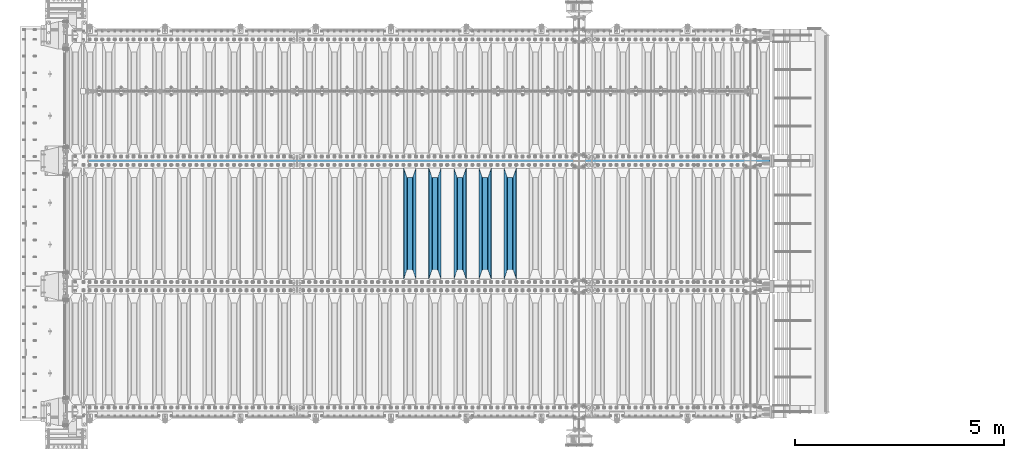
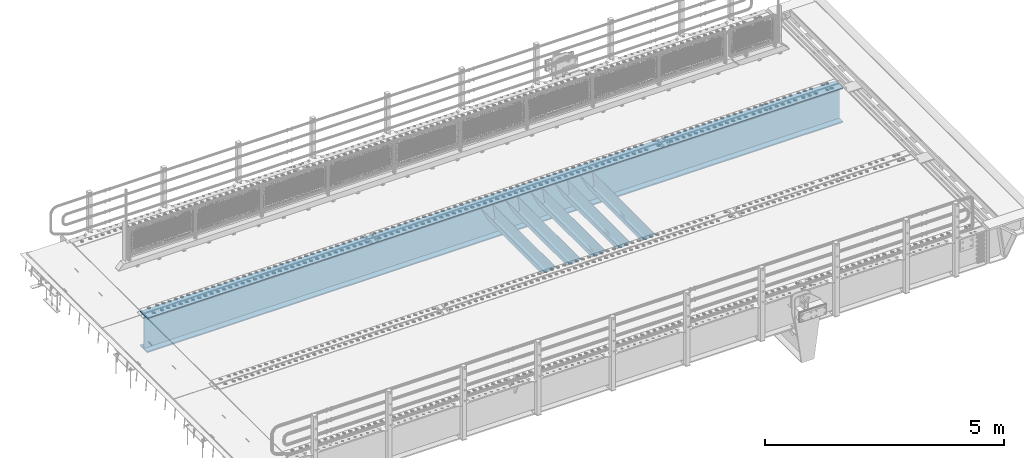
# One storey, part 117 of 247: 6 beams.
"""IFC2X3 building model written with IfcOpenShell, lengths in millimetres."""

from ifc_helpers import new_model, si_unit, frame, origin_with_axes, place, context, subcontext, project, spatial, faceted_brep, material, type_object, element, save


model = new_model("IFC2X3")

# Units and contexts
model_context = context("Model", 3, precision=1e-05, world=origin_with_axes())
body_context = subcontext(model_context, "Body", "Model", "MODEL_VIEW")
ifc_project = project(units=[si_unit("LENGTHUNIT", "METRE", prefix="MILLI"), si_unit("AREAUNIT", "SQUARE_METRE"), si_unit("VOLUMEUNIT", "CUBIC_METRE"), si_unit("MASSUNIT", "GRAM", prefix="KILO"), si_unit("TIMEUNIT", "SECOND"), si_unit("PLANEANGLEUNIT", "RADIAN"), si_unit("SOLIDANGLEUNIT", "STERADIAN"), si_unit("THERMODYNAMICTEMPERATUREUNIT", "DEGREE_CELSIUS"), si_unit("LUMINOUSINTENSITYUNIT", "LUMEN")], contexts=[model_context])

# Site, building, storey
site_placement = place(None, origin_with_axes())
site = spatial("IfcSite", under=ifc_project, at=site_placement, CompositionType="ELEMENT")
building_placement = place(site_placement, origin_with_axes())
building = spatial("IfcBuilding", under=site, at=building_placement, Name="Standard", CompositionType="ELEMENT")
storey_placement = place(building_placement, origin_with_axes())
storey = spatial("IfcBuildingStorey", under=building, at=storey_placement, Name="Undefined", CompositionType="ELEMENT", Elevation=0.0)

# Beams
ifc_material = material(Name="STEEL/S355N")
beam_type_1 = type_object("IfcBeamType", PredefinedType="NOTDEFINED")
beam_1_placement = place(storey_placement, frame((10600.0, 3175.0, -115.0), z_axis=(0.0, 0.0, 1.0), x_axis=(0.0, 1.0, 0.0)))
element("IfcBeam", 1, at=beam_1_placement, inside=storey, type_object=beam_type_1, material=ifc_material, context=body_context, shape_type="Brep", body=[
    faceted_brep([(0.0, 150.0, 115.0), (0.0, 143.689999999999, 115.0), (2650.00000000297, 143.689999999999, 115.0), (2650.00000000297, 150.0, 115.0), (2650.00000000297, 142.059565218402, 110.0000000031), (2650.00000000297, 148.369565218403, 110.0000000031), (2441.90079219208, -80.1103600731112, -98.0992078077845), (2437.7588105432, -77.5672621345584, -102.241189456673), (2434.06523489746, -74.4080125315522, -105.934765102404), (2430.91086095089, -70.710272125576, -109.089139048974), (2428.37322971128, -66.5649389910068, -111.626770288588), (2426.51472138054, -62.0739139532889, -113.485278619323), (2425.38102192091, -57.3475956567672, -114.618978078955), (2424.99999999987, -52.5021667386536, -115.0), (2424.99999999987, 52.5021667386536, -115.0), (2425.38102192091, 57.3475956567672, -114.618978078955), (2426.51472138054, 62.0739139532889, -113.485278619323), (2428.37322971128, 66.5649389910068, -111.626770288588), (2430.91086095089, 70.710272125576, -109.089139048974), (2434.06523489746, 74.4080125315522, -105.934765102404), (2437.7588105432, 77.5672621345584, -102.241189456673), (2441.90079219208, 80.1103600731112, -98.0992078077846), (2446.38936140511, 81.9747917625791, -93.6106385947584), (2448.24948500409, 76.2713538057251, -91.7505149957729), (2444.62967112262, 74.76777986261, -95.3703288772456), (2441.28936334126, 72.7168944282894, -98.710636658607), (2438.31067330438, 70.1691124903846, -101.689326695487), (2435.76682334747, 67.1870637758839, -104.233176652398), (2433.72034654133, 63.8440531834895, -106.279653458539), (2432.22154950041, 60.222258798236, -107.778450499454), (2431.30727574265, 56.4107117849089, -108.692724257221), (2430.99999999987, 52.5031078186876, -109.0), (2430.99999999987, -52.5031078186876, -109.0), (2431.30727574265, -56.4107117849089, -108.692724257221), (2432.22154950041, -60.222258798236, -107.778450499454), (2433.72034654133, -63.8440531834895, -106.279653458539), (2435.76682334747, -67.1870637758839, -104.233176652398), (2438.31067330438, -70.1691124903846, -101.689326695487), (2441.28936334126, -72.7168944282894, -98.7106366586071), (2444.62967112262, -74.76777986261, -95.3703288772457), (2448.24948500409, -76.2713538057251, -91.7505149957729), (2650.00000000297, -142.059565218402, 110.0000000031), (2650.00000000297, -148.369565218403, 110.0000000031), (2446.38936140511, -81.9747917625791, -93.6106385947584), (2650.00000000297, -143.689999999999, 115.0), (2650.00000000297, -150.0, 115.0), (0.0, -143.689999999999, 115.0), (0.0, -150.0, 115.0), (0.0, -148.369565218261, 110.000000002663), (203.610638597422, -81.9747917625791, -93.6106385947584), (208.099207810448, -80.1103600731112, -98.0992078077845), (212.241189459336, -77.5672621345584, -102.241189456673), (215.934765105068, -74.4080125315522, -105.934765102404), (219.089139051637, -70.710272125576, -109.089139048974), (221.626770291251, -66.5649389910068, -111.626770288588), (223.485278621985, -62.0739139532889, -113.485278619323), (224.618978081617, -57.3475956567672, -114.618978078955), (225.000000002663, -52.5021667386536, -115.0), (225.000000002663, 52.5021667386536, -115.0), (224.618978081617, 57.3475956567672, -114.618978078955), (223.485278621985, 62.0739139532889, -113.485278619323), (221.626770291251, 66.5649389910068, -111.626770288588), (219.089139051637, 70.710272125576, -109.089139048974), (215.934765105068, 74.4080125315522, -105.934765102404), (212.241189459336, 77.5672621345584, -102.241189456673), (208.099207810448, 80.1103600731112, -98.0992078077846), (203.610638597422, 81.9747917625791, -93.6106385947584), (0.0, 148.369565218261, 110.000000002663), (0.0, 142.05956521826, 110.000000002663), (201.750514998436, 76.2713538057251, -91.7505149957729), (205.370328879908, 74.76777986261, -95.3703288772456), (208.710636661271, 72.7168944282894, -98.710636658607), (211.68932669815, 70.1691124903846, -101.689326695487), (214.233176655061, 67.1870637758839, -104.233176652398), (216.279653461202, 63.8440531834895, -106.279653458539), (217.778450502117, 60.222258798236, -107.778450499454), (218.692724259885, 56.4107117849089, -108.692724257221), (219.000000002663, 52.5031078186876, -109.0), (219.000000002663, -52.5031078186876, -109.0), (218.692724259885, -56.4107117849089, -108.692724257221), (217.778450502117, -60.222258798236, -107.778450499454), (216.279653461202, -63.8440531834895, -106.279653458539), (214.233176655061, -67.1870637758839, -104.233176652398), (211.68932669815, -70.1691124903846, -101.689326695487), (208.710636661271, -72.7168944282894, -98.7106366586071), (205.370328879908, -74.76777986261, -95.3703288772457), (201.750514998436, -76.2713538057251, -91.7505149957729), (0.0, -142.05956521826, 110.000000002663)], [[[0, 1, 2, 3]], [[3, 2, 4, 5]], [[6, 7, 8, 9, 10, 11, 12, 13, 14, 15, 16, 17, 18, 19, 20, 21, 22, 5, 4, 23, 24, 25, 26, 27, 28, 29, 30, 31, 32, 33, 34, 35, 36, 37, 38, 39, 40, 41, 42, 43]], [[44, 45, 42, 41]], [[46, 47, 45, 44]], [[43, 42, 45, 47, 48, 49]], [[6, 43, 49, 50]], [[7, 6, 50, 51]], [[8, 7, 51, 52]], [[9, 8, 52, 53]], [[10, 9, 53, 54]], [[11, 10, 54, 55]], [[12, 11, 55, 56]], [[13, 12, 56, 57]], [[14, 13, 57, 58]], [[15, 14, 58, 59]], [[16, 15, 59, 60]], [[17, 16, 60, 61]], [[18, 17, 61, 62]], [[19, 18, 62, 63]], [[20, 19, 63, 64]], [[21, 20, 64, 65]], [[22, 21, 65, 66]], [[0, 3, 5, 22, 66, 67]], [[1, 0, 67, 68]], [[23, 4, 2, 1, 68, 69]], [[24, 23, 69, 70]], [[25, 24, 70, 71]], [[26, 25, 71, 72]], [[27, 26, 72, 73]], [[28, 27, 73, 74]], [[29, 28, 74, 75]], [[30, 29, 75, 76]], [[31, 30, 76, 77]], [[32, 31, 77, 78]], [[33, 32, 78, 79]], [[34, 33, 79, 80]], [[35, 34, 80, 81]], [[36, 35, 81, 82]], [[37, 36, 82, 83]], [[38, 37, 83, 84]], [[39, 38, 84, 85]], [[40, 39, 85, 86]], [[46, 44, 41, 40, 86, 87]], [[47, 46, 87, 48]], [[86, 85, 84, 83, 82, 81, 80, 79, 78, 77, 76, 75, 74, 73, 72, 71, 70, 69, 68, 67, 66, 65, 64, 63, 62, 61, 60, 59, 58, 57, 56, 55, 54, 53, 52, 51, 50, 49, 48, 87]]]),
])
beam_2_placement = place(storey_placement, frame((10000.0, 3175.0, -115.0), z_axis=(0.0, 0.0, 1.0), x_axis=(0.0, 1.0, 0.0)))
element("IfcBeam", 2, at=beam_2_placement, inside=storey, type_object=beam_type_1, material=ifc_material, context=body_context, shape_type="Brep", body=[
    faceted_brep([(0.0, 150.0, 115.0), (0.0, 143.689999999999, 115.0), (2650.00000000297, 143.689999999999, 115.0), (2650.00000000297, 150.0, 115.0), (2650.00000000297, 142.059565218402, 110.0000000031), (2650.00000000297, 148.369565218403, 110.0000000031), (2441.90079219208, -80.1103600731112, -98.0992078077845), (2437.7588105432, -77.5672621345584, -102.241189456673), (2434.06523489746, -74.4080125315522, -105.934765102404), (2430.91086095089, -70.710272125576, -109.089139048974), (2428.37322971128, -66.5649389910068, -111.626770288588), (2426.51472138054, -62.0739139532889, -113.485278619323), (2425.38102192091, -57.3475956567672, -114.618978078955), (2424.99999999987, -52.5021667386536, -115.0), (2424.99999999987, 52.5021667386536, -115.0), (2425.38102192091, 57.3475956567672, -114.618978078955), (2426.51472138054, 62.0739139532889, -113.485278619323), (2428.37322971128, 66.5649389910068, -111.626770288588), (2430.91086095089, 70.710272125576, -109.089139048974), (2434.06523489746, 74.4080125315522, -105.934765102404), (2437.7588105432, 77.5672621345584, -102.241189456673), (2441.90079219208, 80.1103600731112, -98.0992078077846), (2446.38936140511, 81.9747917625791, -93.6106385947584), (2448.24948500409, 76.2713538057251, -91.7505149957729), (2444.62967112262, 74.76777986261, -95.3703288772456), (2441.28936334126, 72.7168944282894, -98.710636658607), (2438.31067330438, 70.1691124903846, -101.689326695487), (2435.76682334747, 67.1870637758839, -104.233176652398), (2433.72034654133, 63.8440531834895, -106.279653458539), (2432.22154950041, 60.222258798236, -107.778450499454), (2431.30727574265, 56.4107117849089, -108.692724257221), (2430.99999999987, 52.5031078186876, -109.0), (2430.99999999987, -52.5031078186876, -109.0), (2431.30727574265, -56.4107117849089, -108.692724257221), (2432.22154950041, -60.222258798236, -107.778450499454), (2433.72034654133, -63.8440531834895, -106.279653458539), (2435.76682334747, -67.1870637758839, -104.233176652398), (2438.31067330438, -70.1691124903846, -101.689326695487), (2441.28936334126, -72.7168944282894, -98.7106366586071), (2444.62967112262, -74.76777986261, -95.3703288772457), (2448.24948500409, -76.2713538057251, -91.7505149957729), (2650.00000000297, -142.059565218402, 110.0000000031), (2650.00000000297, -148.369565218403, 110.0000000031), (2446.38936140511, -81.9747917625791, -93.6106385947584), (2650.00000000297, -143.689999999999, 115.0), (2650.00000000297, -150.0, 115.0), (0.0, -143.689999999999, 115.0), (0.0, -150.0, 115.0), (0.0, -148.369565218261, 110.000000002663), (203.610638597422, -81.9747917625791, -93.6106385947584), (208.099207810448, -80.1103600731112, -98.0992078077845), (212.241189459336, -77.5672621345584, -102.241189456673), (215.934765105068, -74.4080125315522, -105.934765102404), (219.089139051637, -70.710272125576, -109.089139048974), (221.626770291251, -66.5649389910068, -111.626770288588), (223.485278621985, -62.0739139532889, -113.485278619323), (224.618978081617, -57.3475956567672, -114.618978078955), (225.000000002663, -52.5021667386536, -115.0), (225.000000002663, 52.5021667386536, -115.0), (224.618978081617, 57.3475956567672, -114.618978078955), (223.485278621985, 62.0739139532889, -113.485278619323), (221.626770291251, 66.5649389910068, -111.626770288588), (219.089139051637, 70.710272125576, -109.089139048974), (215.934765105068, 74.4080125315522, -105.934765102404), (212.241189459336, 77.5672621345584, -102.241189456673), (208.099207810448, 80.1103600731112, -98.0992078077846), (203.610638597422, 81.9747917625791, -93.6106385947584), (0.0, 148.369565218261, 110.000000002663), (0.0, 142.05956521826, 110.000000002663), (201.750514998436, 76.2713538057251, -91.7505149957729), (205.370328879908, 74.76777986261, -95.3703288772456), (208.710636661271, 72.7168944282894, -98.710636658607), (211.68932669815, 70.1691124903846, -101.689326695487), (214.233176655061, 67.1870637758839, -104.233176652398), (216.279653461202, 63.8440531834895, -106.279653458539), (217.778450502117, 60.222258798236, -107.778450499454), (218.692724259885, 56.4107117849089, -108.692724257221), (219.000000002663, 52.5031078186876, -109.0), (219.000000002663, -52.5031078186876, -109.0), (218.692724259885, -56.4107117849089, -108.692724257221), (217.778450502117, -60.222258798236, -107.778450499454), (216.279653461202, -63.8440531834895, -106.279653458539), (214.233176655061, -67.1870637758839, -104.233176652398), (211.68932669815, -70.1691124903846, -101.689326695487), (208.710636661271, -72.7168944282894, -98.7106366586071), (205.370328879908, -74.76777986261, -95.3703288772457), (201.750514998436, -76.2713538057251, -91.7505149957729), (0.0, -142.05956521826, 110.000000002663)], [[[0, 1, 2, 3]], [[3, 2, 4, 5]], [[6, 7, 8, 9, 10, 11, 12, 13, 14, 15, 16, 17, 18, 19, 20, 21, 22, 5, 4, 23, 24, 25, 26, 27, 28, 29, 30, 31, 32, 33, 34, 35, 36, 37, 38, 39, 40, 41, 42, 43]], [[44, 45, 42, 41]], [[46, 47, 45, 44]], [[43, 42, 45, 47, 48, 49]], [[6, 43, 49, 50]], [[7, 6, 50, 51]], [[8, 7, 51, 52]], [[9, 8, 52, 53]], [[10, 9, 53, 54]], [[11, 10, 54, 55]], [[12, 11, 55, 56]], [[13, 12, 56, 57]], [[14, 13, 57, 58]], [[15, 14, 58, 59]], [[16, 15, 59, 60]], [[17, 16, 60, 61]], [[18, 17, 61, 62]], [[19, 18, 62, 63]], [[20, 19, 63, 64]], [[21, 20, 64, 65]], [[22, 21, 65, 66]], [[0, 3, 5, 22, 66, 67]], [[1, 0, 67, 68]], [[23, 4, 2, 1, 68, 69]], [[24, 23, 69, 70]], [[25, 24, 70, 71]], [[26, 25, 71, 72]], [[27, 26, 72, 73]], [[28, 27, 73, 74]], [[29, 28, 74, 75]], [[30, 29, 75, 76]], [[31, 30, 76, 77]], [[32, 31, 77, 78]], [[33, 32, 78, 79]], [[34, 33, 79, 80]], [[35, 34, 80, 81]], [[36, 35, 81, 82]], [[37, 36, 82, 83]], [[38, 37, 83, 84]], [[39, 38, 84, 85]], [[40, 39, 85, 86]], [[46, 44, 41, 40, 86, 87]], [[47, 46, 87, 48]], [[86, 85, 84, 83, 82, 81, 80, 79, 78, 77, 76, 75, 74, 73, 72, 71, 70, 69, 68, 67, 66, 65, 64, 63, 62, 61, 60, 59, 58, 57, 56, 55, 54, 53, 52, 51, 50, 49, 48, 87]]]),
])
beam_3_placement = place(storey_placement, frame((9400.0, 3175.0, -115.0), z_axis=(0.0, 0.0, 1.0), x_axis=(0.0, 1.0, 0.0)))
element("IfcBeam", 3, at=beam_3_placement, inside=storey, type_object=beam_type_1, material=ifc_material, context=body_context, shape_type="Brep", body=[
    faceted_brep([(0.0, 150.0, 115.0), (0.0, 143.689999999999, 115.0), (2650.00000000297, 143.689999999999, 115.0), (2650.00000000297, 150.0, 115.0), (2650.00000000297, 142.059565218402, 110.0000000031), (2650.00000000297, 148.369565218403, 110.0000000031), (2441.90079219208, -80.1103600731112, -98.0992078077845), (2437.7588105432, -77.5672621345584, -102.241189456673), (2434.06523489746, -74.4080125315522, -105.934765102404), (2430.91086095089, -70.710272125576, -109.089139048974), (2428.37322971128, -66.5649389910068, -111.626770288588), (2426.51472138054, -62.0739139532889, -113.485278619323), (2425.38102192091, -57.3475956567672, -114.618978078955), (2424.99999999987, -52.5021667386536, -115.0), (2424.99999999987, 52.5021667386536, -115.0), (2425.38102192091, 57.3475956567672, -114.618978078955), (2426.51472138054, 62.0739139532889, -113.485278619323), (2428.37322971128, 66.5649389910068, -111.626770288588), (2430.91086095089, 70.710272125576, -109.089139048974), (2434.06523489746, 74.4080125315522, -105.934765102404), (2437.7588105432, 77.5672621345584, -102.241189456673), (2441.90079219208, 80.1103600731112, -98.0992078077846), (2446.38936140511, 81.9747917625791, -93.6106385947584), (2448.24948500409, 76.2713538057251, -91.7505149957729), (2444.62967112262, 74.76777986261, -95.3703288772456), (2441.28936334126, 72.7168944282894, -98.710636658607), (2438.31067330438, 70.1691124903846, -101.689326695487), (2435.76682334747, 67.1870637758839, -104.233176652398), (2433.72034654133, 63.8440531834895, -106.279653458539), (2432.22154950041, 60.222258798236, -107.778450499454), (2431.30727574265, 56.4107117849089, -108.692724257221), (2430.99999999987, 52.5031078186876, -109.0), (2430.99999999987, -52.5031078186876, -109.0), (2431.30727574265, -56.4107117849089, -108.692724257221), (2432.22154950041, -60.222258798236, -107.778450499454), (2433.72034654133, -63.8440531834895, -106.279653458539), (2435.76682334747, -67.1870637758839, -104.233176652398), (2438.31067330438, -70.1691124903846, -101.689326695487), (2441.28936334126, -72.7168944282894, -98.7106366586071), (2444.62967112262, -74.76777986261, -95.3703288772457), (2448.24948500409, -76.2713538057251, -91.7505149957729), (2650.00000000297, -142.059565218402, 110.0000000031), (2650.00000000297, -148.369565218403, 110.0000000031), (2446.38936140511, -81.9747917625791, -93.6106385947584), (2650.00000000297, -143.689999999999, 115.0), (2650.00000000297, -150.0, 115.0), (0.0, -143.689999999999, 115.0), (0.0, -150.0, 115.0), (0.0, -148.369565218261, 110.000000002663), (203.610638597422, -81.9747917625791, -93.6106385947584), (208.099207810448, -80.1103600731112, -98.0992078077845), (212.241189459336, -77.5672621345584, -102.241189456673), (215.934765105068, -74.4080125315522, -105.934765102404), (219.089139051637, -70.710272125576, -109.089139048974), (221.626770291251, -66.5649389910068, -111.626770288588), (223.485278621985, -62.0739139532889, -113.485278619323), (224.618978081617, -57.3475956567672, -114.618978078955), (225.000000002663, -52.5021667386536, -115.0), (225.000000002663, 52.5021667386536, -115.0), (224.618978081617, 57.3475956567672, -114.618978078955), (223.485278621985, 62.0739139532889, -113.485278619323), (221.626770291251, 66.5649389910068, -111.626770288588), (219.089139051637, 70.710272125576, -109.089139048974), (215.934765105068, 74.4080125315522, -105.934765102404), (212.241189459336, 77.5672621345584, -102.241189456673), (208.099207810448, 80.1103600731112, -98.0992078077846), (203.610638597422, 81.9747917625791, -93.6106385947584), (0.0, 148.369565218261, 110.000000002663), (0.0, 142.05956521826, 110.000000002663), (201.750514998436, 76.2713538057251, -91.7505149957729), (205.370328879908, 74.76777986261, -95.3703288772456), (208.710636661271, 72.7168944282894, -98.710636658607), (211.68932669815, 70.1691124903846, -101.689326695487), (214.233176655061, 67.1870637758839, -104.233176652398), (216.279653461202, 63.8440531834895, -106.279653458539), (217.778450502117, 60.222258798236, -107.778450499454), (218.692724259885, 56.4107117849089, -108.692724257221), (219.000000002663, 52.5031078186876, -109.0), (219.000000002663, -52.5031078186876, -109.0), (218.692724259885, -56.4107117849089, -108.692724257221), (217.778450502117, -60.222258798236, -107.778450499454), (216.279653461202, -63.8440531834895, -106.279653458539), (214.233176655061, -67.1870637758839, -104.233176652398), (211.68932669815, -70.1691124903846, -101.689326695487), (208.710636661271, -72.7168944282894, -98.7106366586071), (205.370328879908, -74.76777986261, -95.3703288772457), (201.750514998436, -76.2713538057251, -91.7505149957729), (0.0, -142.05956521826, 110.000000002663)], [[[0, 1, 2, 3]], [[3, 2, 4, 5]], [[6, 7, 8, 9, 10, 11, 12, 13, 14, 15, 16, 17, 18, 19, 20, 21, 22, 5, 4, 23, 24, 25, 26, 27, 28, 29, 30, 31, 32, 33, 34, 35, 36, 37, 38, 39, 40, 41, 42, 43]], [[44, 45, 42, 41]], [[46, 47, 45, 44]], [[43, 42, 45, 47, 48, 49]], [[6, 43, 49, 50]], [[7, 6, 50, 51]], [[8, 7, 51, 52]], [[9, 8, 52, 53]], [[10, 9, 53, 54]], [[11, 10, 54, 55]], [[12, 11, 55, 56]], [[13, 12, 56, 57]], [[14, 13, 57, 58]], [[15, 14, 58, 59]], [[16, 15, 59, 60]], [[17, 16, 60, 61]], [[18, 17, 61, 62]], [[19, 18, 62, 63]], [[20, 19, 63, 64]], [[21, 20, 64, 65]], [[22, 21, 65, 66]], [[0, 3, 5, 22, 66, 67]], [[1, 0, 67, 68]], [[23, 4, 2, 1, 68, 69]], [[24, 23, 69, 70]], [[25, 24, 70, 71]], [[26, 25, 71, 72]], [[27, 26, 72, 73]], [[28, 27, 73, 74]], [[29, 28, 74, 75]], [[30, 29, 75, 76]], [[31, 30, 76, 77]], [[32, 31, 77, 78]], [[33, 32, 78, 79]], [[34, 33, 79, 80]], [[35, 34, 80, 81]], [[36, 35, 81, 82]], [[37, 36, 82, 83]], [[38, 37, 83, 84]], [[39, 38, 84, 85]], [[40, 39, 85, 86]], [[46, 44, 41, 40, 86, 87]], [[47, 46, 87, 48]], [[86, 85, 84, 83, 82, 81, 80, 79, 78, 77, 76, 75, 74, 73, 72, 71, 70, 69, 68, 67, 66, 65, 64, 63, 62, 61, 60, 59, 58, 57, 56, 55, 54, 53, 52, 51, 50, 49, 48, 87]]]),
])
beam_4_placement = place(storey_placement, frame((8800.0, 3175.0, -115.0), z_axis=(0.0, 0.0, 1.0), x_axis=(0.0, 1.0, 0.0)))
element("IfcBeam", 4, at=beam_4_placement, inside=storey, type_object=beam_type_1, material=ifc_material, context=body_context, shape_type="Brep", body=[
    faceted_brep([(0.0, 150.0, 115.0), (0.0, 143.689999999999, 115.0), (2650.00000000297, 143.689999999999, 115.0), (2650.00000000297, 150.0, 115.0), (2650.00000000297, 142.059565218402, 110.0000000031), (2650.00000000297, 148.369565218403, 110.0000000031), (2441.90079219208, -80.1103600731112, -98.0992078077845), (2437.7588105432, -77.5672621345584, -102.241189456673), (2434.06523489746, -74.4080125315522, -105.934765102404), (2430.91086095089, -70.710272125576, -109.089139048974), (2428.37322971128, -66.5649389910068, -111.626770288588), (2426.51472138054, -62.0739139532889, -113.485278619323), (2425.38102192091, -57.3475956567672, -114.618978078955), (2424.99999999987, -52.5021667386536, -115.0), (2424.99999999987, 52.5021667386536, -115.0), (2425.38102192091, 57.3475956567672, -114.618978078955), (2426.51472138054, 62.0739139532889, -113.485278619323), (2428.37322971128, 66.5649389910068, -111.626770288588), (2430.91086095089, 70.710272125576, -109.089139048974), (2434.06523489746, 74.4080125315522, -105.934765102404), (2437.7588105432, 77.5672621345584, -102.241189456673), (2441.90079219208, 80.1103600731112, -98.0992078077846), (2446.38936140511, 81.9747917625791, -93.6106385947584), (2448.24948500409, 76.2713538057251, -91.7505149957729), (2444.62967112262, 74.76777986261, -95.3703288772456), (2441.28936334126, 72.7168944282894, -98.710636658607), (2438.31067330438, 70.1691124903846, -101.689326695487), (2435.76682334747, 67.1870637758839, -104.233176652398), (2433.72034654133, 63.8440531834895, -106.279653458539), (2432.22154950041, 60.222258798236, -107.778450499454), (2431.30727574265, 56.4107117849089, -108.692724257221), (2430.99999999987, 52.5031078186876, -109.0), (2430.99999999987, -52.5031078186876, -109.0), (2431.30727574265, -56.4107117849089, -108.692724257221), (2432.22154950041, -60.222258798236, -107.778450499454), (2433.72034654133, -63.8440531834895, -106.279653458539), (2435.76682334747, -67.1870637758839, -104.233176652398), (2438.31067330438, -70.1691124903846, -101.689326695487), (2441.28936334126, -72.7168944282894, -98.7106366586071), (2444.62967112262, -74.76777986261, -95.3703288772457), (2448.24948500409, -76.2713538057251, -91.7505149957729), (2650.00000000297, -142.059565218402, 110.0000000031), (2650.00000000297, -148.369565218403, 110.0000000031), (2446.38936140511, -81.9747917625791, -93.6106385947584), (2650.00000000297, -143.689999999999, 115.0), (2650.00000000297, -150.0, 115.0), (0.0, -143.689999999999, 115.0), (0.0, -150.0, 115.0), (0.0, -148.369565218261, 110.000000002663), (203.610638597422, -81.9747917625791, -93.6106385947584), (208.099207810448, -80.1103600731112, -98.0992078077845), (212.241189459336, -77.5672621345584, -102.241189456673), (215.934765105068, -74.4080125315522, -105.934765102404), (219.089139051637, -70.710272125576, -109.089139048974), (221.626770291251, -66.5649389910068, -111.626770288588), (223.485278621985, -62.0739139532889, -113.485278619323), (224.618978081617, -57.3475956567672, -114.618978078955), (225.000000002663, -52.5021667386536, -115.0), (225.000000002663, 52.5021667386536, -115.0), (224.618978081617, 57.3475956567672, -114.618978078955), (223.485278621985, 62.0739139532889, -113.485278619323), (221.626770291251, 66.5649389910068, -111.626770288588), (219.089139051637, 70.710272125576, -109.089139048974), (215.934765105068, 74.4080125315522, -105.934765102404), (212.241189459336, 77.5672621345584, -102.241189456673), (208.099207810448, 80.1103600731112, -98.0992078077846), (203.610638597422, 81.9747917625791, -93.6106385947584), (0.0, 148.369565218261, 110.000000002663), (0.0, 142.05956521826, 110.000000002663), (201.750514998436, 76.2713538057251, -91.7505149957729), (205.370328879908, 74.76777986261, -95.3703288772456), (208.710636661271, 72.7168944282894, -98.710636658607), (211.68932669815, 70.1691124903846, -101.689326695487), (214.233176655061, 67.1870637758839, -104.233176652398), (216.279653461202, 63.8440531834895, -106.279653458539), (217.778450502117, 60.222258798236, -107.778450499454), (218.692724259885, 56.4107117849089, -108.692724257221), (219.000000002663, 52.5031078186876, -109.0), (219.000000002663, -52.5031078186876, -109.0), (218.692724259885, -56.4107117849089, -108.692724257221), (217.778450502117, -60.222258798236, -107.778450499454), (216.279653461202, -63.8440531834895, -106.279653458539), (214.233176655061, -67.1870637758839, -104.233176652398), (211.68932669815, -70.1691124903846, -101.689326695487), (208.710636661271, -72.7168944282894, -98.7106366586071), (205.370328879908, -74.76777986261, -95.3703288772457), (201.750514998436, -76.2713538057251, -91.7505149957729), (0.0, -142.05956521826, 110.000000002663)], [[[0, 1, 2, 3]], [[3, 2, 4, 5]], [[6, 7, 8, 9, 10, 11, 12, 13, 14, 15, 16, 17, 18, 19, 20, 21, 22, 5, 4, 23, 24, 25, 26, 27, 28, 29, 30, 31, 32, 33, 34, 35, 36, 37, 38, 39, 40, 41, 42, 43]], [[44, 45, 42, 41]], [[46, 47, 45, 44]], [[43, 42, 45, 47, 48, 49]], [[6, 43, 49, 50]], [[7, 6, 50, 51]], [[8, 7, 51, 52]], [[9, 8, 52, 53]], [[10, 9, 53, 54]], [[11, 10, 54, 55]], [[12, 11, 55, 56]], [[13, 12, 56, 57]], [[14, 13, 57, 58]], [[15, 14, 58, 59]], [[16, 15, 59, 60]], [[17, 16, 60, 61]], [[18, 17, 61, 62]], [[19, 18, 62, 63]], [[20, 19, 63, 64]], [[21, 20, 64, 65]], [[22, 21, 65, 66]], [[0, 3, 5, 22, 66, 67]], [[1, 0, 67, 68]], [[23, 4, 2, 1, 68, 69]], [[24, 23, 69, 70]], [[25, 24, 70, 71]], [[26, 25, 71, 72]], [[27, 26, 72, 73]], [[28, 27, 73, 74]], [[29, 28, 74, 75]], [[30, 29, 75, 76]], [[31, 30, 76, 77]], [[32, 31, 77, 78]], [[33, 32, 78, 79]], [[34, 33, 79, 80]], [[35, 34, 80, 81]], [[36, 35, 81, 82]], [[37, 36, 82, 83]], [[38, 37, 83, 84]], [[39, 38, 84, 85]], [[40, 39, 85, 86]], [[46, 44, 41, 40, 86, 87]], [[47, 46, 87, 48]], [[86, 85, 84, 83, 82, 81, 80, 79, 78, 77, 76, 75, 74, 73, 72, 71, 70, 69, 68, 67, 66, 65, 64, 63, 62, 61, 60, 59, 58, 57, 56, 55, 54, 53, 52, 51, 50, 49, 48, 87]]]),
])
beam_5_placement = place(storey_placement, frame((8200.0, 3175.0, -115.0), z_axis=(0.0, 0.0, 1.0), x_axis=(0.0, 1.0, 0.0)))
element("IfcBeam", 5, at=beam_5_placement, inside=storey, type_object=beam_type_1, material=ifc_material, context=body_context, shape_type="Brep", body=[
    faceted_brep([(0.0, 150.0, 115.0), (0.0, 143.689999999999, 115.0), (2650.00000000297, 143.689999999999, 115.0), (2650.00000000297, 150.0, 115.0), (2650.00000000297, 142.059565218402, 110.0000000031), (2650.00000000297, 148.369565218403, 110.0000000031), (2441.90079219208, -80.1103600731112, -98.0992078077845), (2437.7588105432, -77.5672621345584, -102.241189456673), (2434.06523489746, -74.4080125315522, -105.934765102404), (2430.91086095089, -70.710272125576, -109.089139048974), (2428.37322971128, -66.5649389910068, -111.626770288588), (2426.51472138054, -62.0739139532889, -113.485278619323), (2425.38102192091, -57.3475956567672, -114.618978078955), (2424.99999999987, -52.5021667386536, -115.0), (2424.99999999987, 52.5021667386536, -115.0), (2425.38102192091, 57.3475956567672, -114.618978078955), (2426.51472138054, 62.0739139532889, -113.485278619323), (2428.37322971128, 66.5649389910068, -111.626770288588), (2430.91086095089, 70.710272125576, -109.089139048974), (2434.06523489746, 74.4080125315522, -105.934765102404), (2437.7588105432, 77.5672621345584, -102.241189456673), (2441.90079219208, 80.1103600731112, -98.0992078077846), (2446.38936140511, 81.9747917625791, -93.6106385947584), (2448.24948500409, 76.2713538057251, -91.7505149957729), (2444.62967112262, 74.76777986261, -95.3703288772456), (2441.28936334126, 72.7168944282894, -98.710636658607), (2438.31067330438, 70.1691124903846, -101.689326695487), (2435.76682334747, 67.1870637758839, -104.233176652398), (2433.72034654133, 63.8440531834895, -106.279653458539), (2432.22154950041, 60.222258798236, -107.778450499454), (2431.30727574265, 56.4107117849089, -108.692724257221), (2430.99999999987, 52.5031078186876, -109.0), (2430.99999999987, -52.5031078186876, -109.0), (2431.30727574265, -56.4107117849089, -108.692724257221), (2432.22154950041, -60.222258798236, -107.778450499454), (2433.72034654133, -63.8440531834895, -106.279653458539), (2435.76682334747, -67.1870637758839, -104.233176652398), (2438.31067330438, -70.1691124903846, -101.689326695487), (2441.28936334126, -72.7168944282894, -98.7106366586071), (2444.62967112262, -74.76777986261, -95.3703288772457), (2448.24948500409, -76.2713538057251, -91.7505149957729), (2650.00000000297, -142.059565218402, 110.0000000031), (2650.00000000297, -148.369565218403, 110.0000000031), (2446.38936140511, -81.9747917625791, -93.6106385947584), (2650.00000000297, -143.689999999999, 115.0), (2650.00000000297, -150.0, 115.0), (0.0, -143.689999999999, 115.0), (0.0, -150.0, 115.0), (0.0, -148.369565218261, 110.000000002663), (203.610638597422, -81.9747917625791, -93.6106385947584), (208.099207810448, -80.1103600731112, -98.0992078077845), (212.241189459336, -77.5672621345584, -102.241189456673), (215.934765105068, -74.4080125315522, -105.934765102404), (219.089139051637, -70.710272125576, -109.089139048974), (221.626770291251, -66.5649389910068, -111.626770288588), (223.485278621985, -62.0739139532889, -113.485278619323), (224.618978081617, -57.3475956567672, -114.618978078955), (225.000000002663, -52.5021667386536, -115.0), (225.000000002663, 52.5021667386536, -115.0), (224.618978081617, 57.3475956567672, -114.618978078955), (223.485278621985, 62.0739139532889, -113.485278619323), (221.626770291251, 66.5649389910068, -111.626770288588), (219.089139051637, 70.710272125576, -109.089139048974), (215.934765105068, 74.4080125315522, -105.934765102404), (212.241189459336, 77.5672621345584, -102.241189456673), (208.099207810448, 80.1103600731112, -98.0992078077846), (203.610638597422, 81.9747917625791, -93.6106385947584), (0.0, 148.369565218261, 110.000000002663), (0.0, 142.05956521826, 110.000000002663), (201.750514998436, 76.2713538057251, -91.7505149957729), (205.370328879908, 74.76777986261, -95.3703288772456), (208.710636661271, 72.7168944282894, -98.710636658607), (211.68932669815, 70.1691124903846, -101.689326695487), (214.233176655061, 67.1870637758839, -104.233176652398), (216.279653461202, 63.8440531834895, -106.279653458539), (217.778450502117, 60.222258798236, -107.778450499454), (218.692724259885, 56.4107117849089, -108.692724257221), (219.000000002663, 52.5031078186876, -109.0), (219.000000002663, -52.5031078186876, -109.0), (218.692724259885, -56.4107117849089, -108.692724257221), (217.778450502117, -60.222258798236, -107.778450499454), (216.279653461202, -63.8440531834895, -106.279653458539), (214.233176655061, -67.1870637758839, -104.233176652398), (211.68932669815, -70.1691124903846, -101.689326695487), (208.710636661271, -72.7168944282894, -98.7106366586071), (205.370328879908, -74.76777986261, -95.3703288772457), (201.750514998436, -76.2713538057251, -91.7505149957729), (0.0, -142.05956521826, 110.000000002663)], [[[0, 1, 2, 3]], [[3, 2, 4, 5]], [[6, 7, 8, 9, 10, 11, 12, 13, 14, 15, 16, 17, 18, 19, 20, 21, 22, 5, 4, 23, 24, 25, 26, 27, 28, 29, 30, 31, 32, 33, 34, 35, 36, 37, 38, 39, 40, 41, 42, 43]], [[44, 45, 42, 41]], [[46, 47, 45, 44]], [[43, 42, 45, 47, 48, 49]], [[6, 43, 49, 50]], [[7, 6, 50, 51]], [[8, 7, 51, 52]], [[9, 8, 52, 53]], [[10, 9, 53, 54]], [[11, 10, 54, 55]], [[12, 11, 55, 56]], [[13, 12, 56, 57]], [[14, 13, 57, 58]], [[15, 14, 58, 59]], [[16, 15, 59, 60]], [[17, 16, 60, 61]], [[18, 17, 61, 62]], [[19, 18, 62, 63]], [[20, 19, 63, 64]], [[21, 20, 64, 65]], [[22, 21, 65, 66]], [[0, 3, 5, 22, 66, 67]], [[1, 0, 67, 68]], [[23, 4, 2, 1, 68, 69]], [[24, 23, 69, 70]], [[25, 24, 70, 71]], [[26, 25, 71, 72]], [[27, 26, 72, 73]], [[28, 27, 73, 74]], [[29, 28, 74, 75]], [[30, 29, 75, 76]], [[31, 30, 76, 77]], [[32, 31, 77, 78]], [[33, 32, 78, 79]], [[34, 33, 79, 80]], [[35, 34, 80, 81]], [[36, 35, 81, 82]], [[37, 36, 82, 83]], [[38, 37, 83, 84]], [[39, 38, 84, 85]], [[40, 39, 85, 86]], [[46, 44, 41, 40, 86, 87]], [[47, 46, 87, 48]], [[86, 85, 84, 83, 82, 81, 80, 79, 78, 77, 76, 75, 74, 73, 72, 71, 70, 69, 68, 67, 66, 65, 64, 63, 62, 61, 60, 59, 58, 57, 56, 55, 54, 53, 52, 51, 50, 49, 48, 87]]]),
])
beam_type_2 = type_object("IfcBeamType", Name="HEA900", PredefinedType="NOTDEFINED")
beam_6_placement = place(storey_placement, frame((10.0, 6000.0, -445.0), z_axis=(0.0, 0.0, 1.0), x_axis=(1.0, 0.0, 0.0)))
element("IfcBeam", 6, at=beam_6_placement, inside=storey, type_object=beam_type_2, material=ifc_material, ObjectType="HEA900", context=body_context, shape_type="Brep", body=[
    faceted_brep([(0.0, 150.0, -445.0), (0.0, 150.0, -415.0), (16807.0, 150.0, -415.0), (16807.0, 150.0, -445.0), (0.0, 8.0, -415.0), (16807.0, 8.0, -415.0), (0.0, 8.0, 415.0), (16807.0, 8.0, 415.0), (0.0, 150.0, 415.0), (16807.0, 150.0, 415.0), (0.0, 150.0, 445.0), (16807.0, 150.0, 445.0), (0.0, -150.0, 445.0), (16807.0, -150.0, 445.0), (0.0, -150.0, 415.0), (16807.0, -150.0, 415.0), (0.0, -8.0, 415.0), (16807.0, -8.0, 415.0), (0.0, -8.0, -415.0), (16807.0, -8.0, -415.0), (0.0, -150.0, -415.0), (16807.0, -150.0, -415.0), (0.0, -150.0, -445.0), (16807.0, -150.0, -445.0)], [[[0, 1, 2, 3]], [[1, 4, 5, 2]], [[4, 6, 7, 5]], [[6, 8, 9, 7]], [[8, 10, 11, 9]], [[10, 12, 13, 11]], [[12, 14, 15, 13]], [[14, 16, 17, 15]], [[16, 18, 19, 17]], [[18, 20, 21, 19]], [[20, 22, 23, 21]], [[22, 0, 3, 23]], [[5, 7, 9, 11, 13, 15, 17, 19, 21, 23, 3, 2]], [[22, 20, 18, 16, 14, 12, 10, 8, 6, 4, 1, 0]]]),
])

save(model, "model.ifc")
